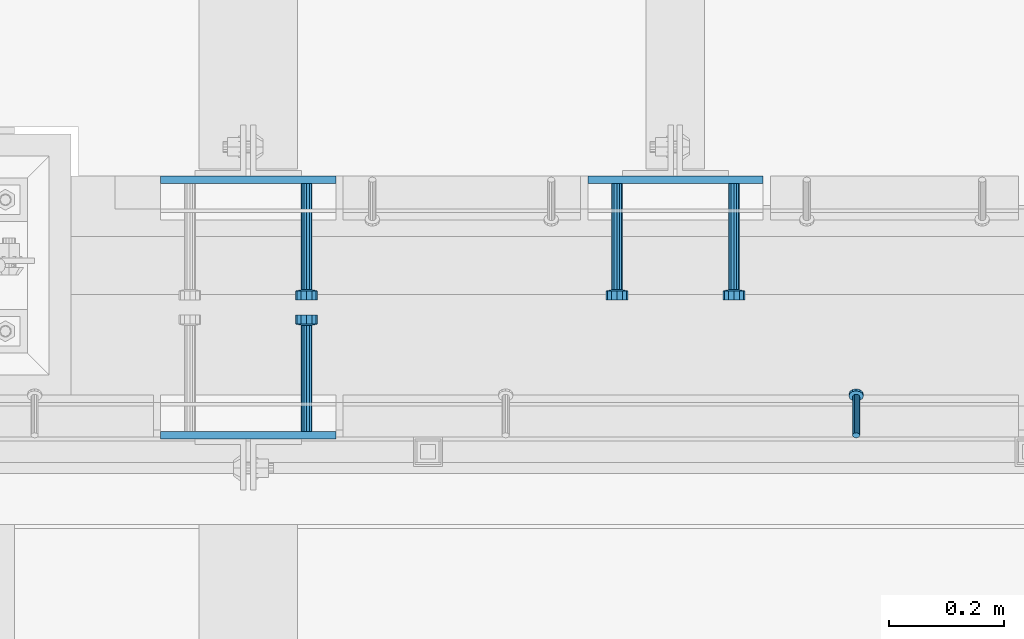
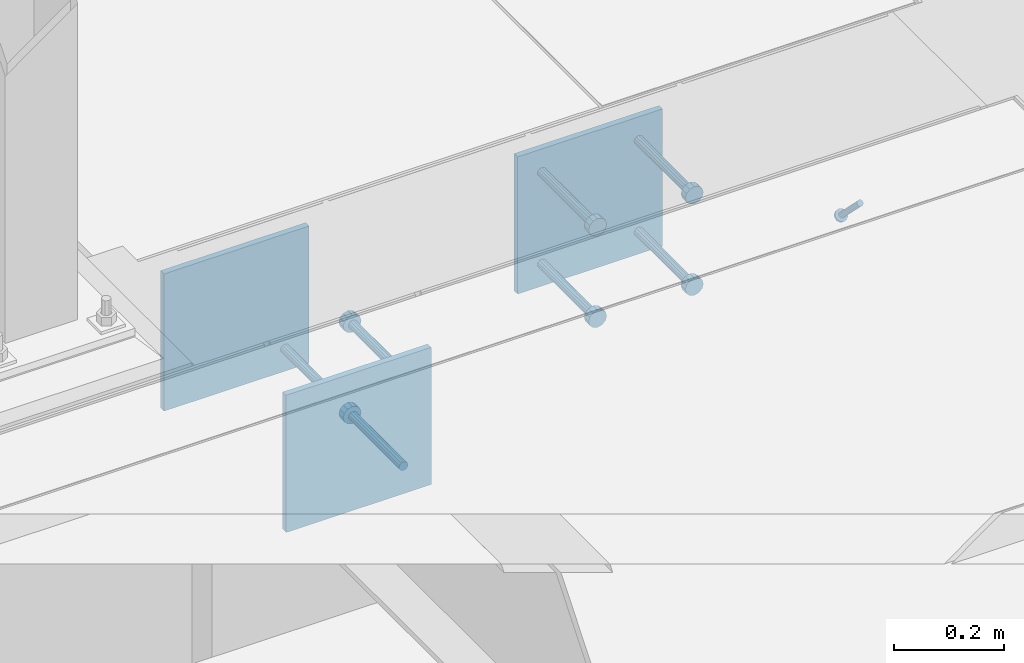
# One storey, part 2067 of 3843: 10 beams, 1 member, 4 elements without a shape of their own.
"""IFC2X3 building model written with IfcOpenShell, lengths in millimetres."""

from ifc_helpers import new_model, si_unit, frame, origin_with_axes, place, context, subcontext, project, spatial, faceted_brep, material, type_object, element, aggregate, save


model = new_model("IFC2X3")

# Units and contexts
model_context = context("Model", 3, precision=1e-05, world=origin_with_axes())
body_context = subcontext(model_context, "Body", "Model", "MODEL_VIEW")
ifc_project = project(units=[si_unit("LENGTHUNIT", "METRE", prefix="MILLI"), si_unit("AREAUNIT", "SQUARE_METRE"), si_unit("VOLUMEUNIT", "CUBIC_METRE"), si_unit("MASSUNIT", "GRAM", prefix="KILO"), si_unit("TIMEUNIT", "SECOND"), si_unit("PLANEANGLEUNIT", "RADIAN"), si_unit("SOLIDANGLEUNIT", "STERADIAN"), si_unit("THERMODYNAMICTEMPERATUREUNIT", "DEGREE_CELSIUS"), si_unit("LUMINOUSINTENSITYUNIT", "LUMEN")], contexts=[model_context])

# Site, building, storey
site_placement = place(None, origin_with_axes())
site = spatial("IfcSite", under=ifc_project, at=site_placement, CompositionType="ELEMENT")
building_placement = place(site_placement, origin_with_axes())
building = spatial("IfcBuilding", under=site, at=building_placement, Name="Undefined", CompositionType="ELEMENT")
storey_placement = place(building_placement, origin_with_axes())
storey = spatial("IfcBuildingStorey", under=building, at=storey_placement, Name="Undefined", CompositionType="ELEMENT", Elevation=0.0)

# Assembly, member
assembly_1_placement = place(storey_placement, origin_with_axes())
assembly_1 = element("IfcElementAssembly", 1, at=assembly_1_placement, inside=storey, Name="ANGLE", AssemblyPlace="NOTDEFINED", PredefinedType="RIGID_FRAME")
ifc_material_1 = material(Name="STEEL/A108")
member_type = type_object("IfcMemberType", PredefinedType="NOTDEFINED")
member_placement = place(assembly_1_placement, frame((50590.4497619755, 20012.0250010032, 30397.4500030497), z_axis=(-1.0, 0.0, 0.0), x_axis=(5.70000238222118e-08, 0.707106781186546, -0.707106781186546)))
member = element("IfcMember", 2, at=member_placement, type_object=member_type, material=ifc_material_1, Name="HEADED STUD ANCHOR", context=body_context, shape_type="Brep", body=[
    faceted_brep([(7.27595761418343e-12, -3.18000006675175, 5.5), (0.0, -5.49999999998363, 3.1800000667572), (94.4879985803855, -5.50000000011278, 3.1800000667572), (94.4879985803782, -3.18000006687362, 5.5), (0.0, -6.3499999046162, 0.0), (94.4879985803855, -6.34999990474535, 0.0), (0.0, -5.49999999998363, -3.1800000667572), (94.4879985803855, -5.50000000011278, -3.1800000667572), (7.27595761418343e-12, -3.18000006675175, -5.5), (94.4879985803782, -3.18000006687362, -5.5), (7.27595761418343e-12, -1.81898940354586e-12, -6.34999990463257), (94.4879985803782, -1.20053300634027e-10, -6.34999990463257), (0.0, 3.18000006675175, -5.5), (94.4879985803709, 3.18000006663351, -5.5), (7.27595761418343e-12, 5.49999999998363, -3.1800000667572), (94.4879985803709, 5.49999999987267, -3.1800000667572), (7.27595761418343e-12, 6.3499999046162, 0.0), (94.4879985803673, 6.34999990450706, 0.0), (7.27595761418343e-12, 5.49999999998363, 3.1800000667572), (94.4879985803709, 5.49999999987267, 3.1800000667572), (0.0, 3.18000006675175, 5.5), (94.4879985803709, 3.18000006663351, 5.5), (7.27595761418343e-12, -1.81898940354586e-12, 6.34999990463257), (94.4879985803782, -1.20053300634027e-10, 6.34999990463257), (96.5199985498621, -10.9899997712273, 6.34999990463257), (96.5199985498548, -6.34000015270249, 10.9899997711182), (96.5199985498621, -12.6999998093743, 0.0), (96.5199985498621, -10.9899997712273, -6.34999990463257), (96.5199985498548, -6.34000015270249, -10.9899997711182), (96.5199985498475, -1.21872290037572e-10, -12.6899995803833), (96.5199985498402, 6.34000015245874, -10.9899997711182), (96.519998549833, 10.9899997709817, -6.34999990463257), (96.519998549833, 12.6999998091305, 0.0), (96.519998549833, 10.9899997709817, 6.34999990463257), (96.5199985498402, 6.34000015245874, 10.9899997711182), (96.5199985498475, -1.21872290037572e-10, 12.6899995803833), (101.599998473539, -10.9899997712328, 6.34999990463257), (101.599998473532, -6.34000015270976, 10.9899997711182), (101.599998473539, -12.6999998093797, 0.0), (101.599998473539, -10.9899997712328, -6.34999990463257), (101.599998473532, -6.34000015270976, -10.9899997711182), (101.599998473524, -1.29148247651756e-10, -12.6899995803833), (101.599998473517, 6.34000015245329, -10.9899997711182), (101.59999847351, 10.9899997709763, -6.34999990463257), (101.599998473503, 12.6999998091196, 0.0), (101.59999847351, 10.9899997709763, 6.34999990463257), (101.599998473517, 6.34000015245329, 10.9899997711182), (101.599998473524, -1.29148247651756e-10, 12.6899995803833)], [[[0, 1, 2, 3]], [[1, 4, 5, 2]], [[4, 6, 7, 5]], [[6, 8, 9, 7]], [[8, 10, 11, 9]], [[10, 12, 13, 11]], [[12, 14, 15, 13]], [[14, 16, 17, 15]], [[16, 18, 19, 17]], [[18, 20, 21, 19]], [[20, 22, 23, 21]], [[22, 0, 3, 23]], [[22, 20, 18, 16, 14, 12, 10, 8, 6, 4, 1, 0]], [[3, 2, 24, 25]], [[2, 5, 26, 24]], [[5, 7, 27, 26]], [[7, 9, 28, 27]], [[9, 11, 29, 28]], [[11, 13, 30, 29]], [[13, 15, 31, 30]], [[15, 17, 32, 31]], [[17, 19, 33, 32]], [[19, 21, 34, 33]], [[21, 23, 35, 34]], [[23, 3, 25, 35]], [[25, 24, 36, 37]], [[24, 26, 38, 36]], [[26, 27, 39, 38]], [[27, 28, 40, 39]], [[28, 29, 41, 40]], [[29, 30, 42, 41]], [[30, 31, 43, 42]], [[31, 32, 44, 43]], [[32, 33, 45, 44]], [[33, 34, 46, 45]], [[34, 35, 47, 46]], [[35, 25, 37, 47]], [[38, 39, 40, 41, 42, 43, 44, 45, 46, 47, 37, 36]]]),
])
aggregate(assembly_1, [member])

# Assembly, beam
assembly_2_placement = place(storey_placement, origin_with_axes())
assembly_2 = element("IfcElementAssembly", 3, at=assembly_2_placement, inside=storey, Name="EMBED PLATE", AssemblyPlace="NOTDEFINED", PredefinedType="RIGID_FRAME")
ifc_material_2 = material(Name="STEEL/A36")
beam_type_1 = type_object("IfcBeamType", PredefinedType="NOTDEFINED")
beam_1_placement = place(assembly_2_placement, frame((49533.175, 20456.5250030517, 30397.45), z_axis=(-1.0, 0.0, 0.0), x_axis=(0.0, 0.0, -1.0)))
beam_1 = element("IfcBeam", 4, at=beam_1_placement, type_object=beam_type_1, material=ifc_material_2, Name="EMBED PLATE", context=body_context, shape_type="Brep", body=[
    faceted_brep([(-1.0550138540566e-10, 6.34999999999854, -152.400000000664), (1.0550138540566e-10, 6.34999999999854, 152.400000000656), (304.799999999999, 6.34999999999854, 152.400000000001), (304.799999999999, 6.34999999999854, -152.400000000001), (1.0550138540566e-10, -6.34999999999854, 152.400000000656), (304.799999999999, -6.34999999999854, 152.400000000001), (-1.0550138540566e-10, -6.34999999999854, -152.400000000664), (304.799999999999, -6.34999999999854, -152.400000000001)], [[[0, 1, 2, 3]], [[1, 4, 5, 2]], [[4, 6, 7, 5]], [[6, 0, 3, 7]], [[5, 7, 3, 2]], [[6, 4, 1, 0]]]),
])

assembly_3_placement = place(storey_placement, origin_with_axes())
assembly_3 = element("IfcElementAssembly", 5, at=assembly_3_placement, inside=storey, Name="EMBED PLATE", AssemblyPlace="NOTDEFINED", PredefinedType="RIGID_FRAME")
beam_2_placement = place(assembly_3_placement, frame((50276.125, 20456.5250030517, 30397.45), z_axis=(-1.0, 0.0, 0.0), x_axis=(0.0, 0.0, -1.0)))
beam_2 = element("IfcBeam", 6, at=beam_2_placement, type_object=beam_type_1, material=ifc_material_2, Name="EMBED PLATE", context=body_context, shape_type="Brep", body=[
    faceted_brep([(-1.0550138540566e-10, 6.34999999999854, -152.400000000664), (1.0550138540566e-10, 6.34999999999854, 152.400000000656), (304.799999999999, 6.34999999999854, 152.400000000001), (304.799999999999, 6.34999999999854, -152.400000000001), (1.0550138540566e-10, -6.34999999999854, 152.400000000656), (304.799999999999, -6.34999999999854, 152.400000000001), (-1.0550138540566e-10, -6.34999999999854, -152.400000000664), (304.799999999999, -6.34999999999854, -152.400000000001)], [[[0, 1, 2, 3]], [[1, 4, 5, 2]], [[4, 6, 7, 5]], [[6, 0, 3, 7]], [[5, 7, 3, 2]], [[6, 4, 1, 0]]]),
])

assembly_4_placement = place(storey_placement, origin_with_axes())
assembly_4 = element("IfcElementAssembly", 7, at=assembly_4_placement, inside=storey, Name="EMBED PLATE", AssemblyPlace="NOTDEFINED", PredefinedType="RIGID_FRAME")
beam_3_placement = place(assembly_4_placement, frame((49533.175, 20012.0249969482, 30397.45), z_axis=(1.0, 0.0, 0.0), x_axis=(0.0, 0.0, -1.0)))
beam_3 = element("IfcBeam", 8, at=beam_3_placement, type_object=beam_type_1, material=ifc_material_2, Name="EMBED PLATE", context=body_context, shape_type="Brep", body=[
    faceted_brep([(-1.0550138540566e-10, 6.34999999999854, -152.400000000664), (1.0550138540566e-10, 6.34999999999854, 152.400000000656), (304.799999999999, 6.34999999999854, 152.400000000001), (304.799999999999, 6.34999999999854, -152.400000000001), (1.0550138540566e-10, -6.34999999999854, 152.400000000656), (304.799999999999, -6.34999999999854, 152.400000000001), (-1.0550138540566e-10, -6.34999999999854, -152.400000000664), (304.799999999999, -6.34999999999854, -152.400000000001)], [[[0, 1, 2, 3]], [[1, 4, 5, 2]], [[4, 6, 7, 5]], [[6, 0, 3, 7]], [[5, 7, 3, 2]], [[6, 4, 1, 0]]]),
])

# Beam
beam_type_2 = type_object("IfcBeamType", PredefinedType="NOTDEFINED")
beam_4_placement = place(assembly_2_placement, frame((49634.775, 20450.1750030517, 30143.45), z_axis=(1.0, 0.0, 0.0), x_axis=(0.0, -1.0, 0.0)))
beam_4 = element("IfcBeam", 9, at=beam_4_placement, type_object=beam_type_2, material=ifc_material_1, Name="HEADED STUD ANCHOR", context=body_context, shape_type="Brep", body=[
    faceted_brep([(0.0, -9.52000045776367, 0.0), (0.0, -8.25, -4.76000022888184), (184.912000000004, -8.25, -4.76000022888184), (184.912000000004, -9.52000045776367, 0.0), (0.0, -4.76000022888184, -8.25), (184.912000000004, -4.76000022888184, -8.25), (0.0, 0.0, -9.52000045776367), (184.912000000004, 0.0, -9.52000045776367), (0.0, 4.76000022888184, -8.25), (184.912000000004, 4.76000022888184, -8.25), (0.0, 8.25, -4.76000022888184), (184.912000000004, 8.25, -4.76000022888184), (0.0, 9.52000045776367, 0.0), (184.912000000004, 9.52000045776367, 0.0), (0.0, 8.25, 4.76000022888184), (184.912000000004, 8.25, 4.76000022888184), (0.0, 4.76000022888184, 8.25), (184.912000000004, 4.76000022888184, 8.25), (0.0, 0.0, 9.52000045776367), (184.912000000004, 0.0, 9.52000045776367), (0.0, -4.76000022888184, 8.25), (184.912000000004, -4.76000022888184, 8.25), (0.0, -8.25, 4.76000022888184), (184.912000000004, -8.25, 4.76000022888184), (186.944000000003, -16.5, -9.52000045776367), (186.944000000003, -19.0499992370605, 0.0), (186.944000000003, -9.52000045776367, -16.5), (186.944000000003, 0.0, -19.0499992370605), (186.944000000003, 9.52000045776367, -16.5), (186.944000000003, 16.5, -9.52000045776367), (186.944000000003, 19.0499992370605, 0.0), (186.944000000003, 16.5, 9.52000045776367), (186.944000000003, 9.52000045776367, 16.5), (186.944000000003, 0.0, 19.0499992370605), (186.944000000003, -9.52000045776367, 16.5), (186.944000000003, -16.5, 9.52000045776367), (203.199999999997, -16.5, -9.52000045776367), (203.199999999997, -19.0499992370605, 0.0), (203.199999999997, -9.52000045776367, -16.5), (203.199999999997, 0.0, -19.0499992370605), (203.199999999997, 9.52000045776367, -16.5), (203.199999999997, 16.5, -9.52000045776367), (203.199999999997, 19.0499992370605, 0.0), (203.199999999997, 16.5, 9.52000045776367), (203.199999999997, 9.52000045776367, 16.5), (203.199999999997, 0.0, 19.0499992370605), (203.199999999997, -9.52000045776367, 16.5), (203.199999999997, -16.5, 9.52000045776367)], [[[0, 1, 2, 3]], [[1, 4, 5, 2]], [[4, 6, 7, 5]], [[6, 8, 9, 7]], [[8, 10, 11, 9]], [[10, 12, 13, 11]], [[12, 14, 15, 13]], [[14, 16, 17, 15]], [[16, 18, 19, 17]], [[18, 20, 21, 19]], [[20, 22, 23, 21]], [[22, 0, 3, 23]], [[22, 20, 18, 16, 14, 12, 10, 8, 6, 4, 1, 0]], [[3, 2, 24, 25]], [[2, 5, 26, 24]], [[5, 7, 27, 26]], [[7, 9, 28, 27]], [[9, 11, 29, 28]], [[11, 13, 30, 29]], [[13, 15, 31, 30]], [[15, 17, 32, 31]], [[17, 19, 33, 32]], [[19, 21, 34, 33]], [[21, 23, 35, 34]], [[23, 3, 25, 35]], [[25, 24, 36, 37]], [[24, 26, 38, 36]], [[26, 27, 39, 38]], [[27, 28, 40, 39]], [[28, 29, 41, 40]], [[29, 30, 42, 41]], [[30, 31, 43, 42]], [[31, 32, 44, 43]], [[32, 33, 45, 44]], [[33, 34, 46, 45]], [[34, 35, 47, 46]], [[35, 25, 37, 47]], [[38, 39, 40, 41, 42, 43, 44, 45, 46, 47, 37, 36]]]),
])

aggregate(assembly_2, [beam_4, beam_1])

beam_5_placement = place(assembly_3_placement, frame((50377.725, 20450.1750030517, 30346.65), z_axis=(1.0, 0.0, 0.0), x_axis=(0.0, -1.0, 0.0)))
beam_5 = element("IfcBeam", 10, at=beam_5_placement, type_object=beam_type_2, material=ifc_material_1, Name="HEADED STUD ANCHOR", context=body_context, shape_type="Brep", body=[
    faceted_brep([(0.0, -9.52000045776367, 0.0), (0.0, -8.25, -4.76000022888184), (184.912000000004, -8.25, -4.76000022888184), (184.912000000004, -9.52000045776367, 0.0), (0.0, -4.76000022888184, -8.25), (184.912000000004, -4.76000022888184, -8.25), (0.0, 0.0, -9.52000045776367), (184.912000000004, 0.0, -9.52000045776367), (0.0, 4.76000022888184, -8.25), (184.912000000004, 4.76000022888184, -8.25), (0.0, 8.25, -4.76000022888184), (184.912000000004, 8.25, -4.76000022888184), (0.0, 9.52000045776367, 0.0), (184.912000000004, 9.52000045776367, 0.0), (0.0, 8.25, 4.76000022888184), (184.912000000004, 8.25, 4.76000022888184), (0.0, 4.76000022888184, 8.25), (184.912000000004, 4.76000022888184, 8.25), (0.0, 0.0, 9.52000045776367), (184.912000000004, 0.0, 9.52000045776367), (0.0, -4.76000022888184, 8.25), (184.912000000004, -4.76000022888184, 8.25), (0.0, -8.25, 4.76000022888184), (184.912000000004, -8.25, 4.76000022888184), (186.944000000003, -16.5, -9.52000045776367), (186.944000000003, -19.0499992370605, 0.0), (186.944000000003, -9.52000045776367, -16.5), (186.944000000003, 0.0, -19.0499992370605), (186.944000000003, 9.52000045776367, -16.5), (186.944000000003, 16.5, -9.52000045776367), (186.944000000003, 19.0499992370605, 0.0), (186.944000000003, 16.5, 9.52000045776367), (186.944000000003, 9.52000045776367, 16.5), (186.944000000003, 0.0, 19.0499992370605), (186.944000000003, -9.52000045776367, 16.5), (186.944000000003, -16.5, 9.52000045776367), (203.199999999997, -16.5, -9.52000045776367), (203.199999999997, -19.0499992370605, 0.0), (203.199999999997, -9.52000045776367, -16.5), (203.199999999997, 0.0, -19.0499992370605), (203.199999999997, 9.52000045776367, -16.5), (203.199999999997, 16.5, -9.52000045776367), (203.199999999997, 19.0499992370605, 0.0), (203.199999999997, 16.5, 9.52000045776367), (203.199999999997, 9.52000045776367, 16.5), (203.199999999997, 0.0, 19.0499992370605), (203.199999999997, -9.52000045776367, 16.5), (203.199999999997, -16.5, 9.52000045776367)], [[[0, 1, 2, 3]], [[1, 4, 5, 2]], [[4, 6, 7, 5]], [[6, 8, 9, 7]], [[8, 10, 11, 9]], [[10, 12, 13, 11]], [[12, 14, 15, 13]], [[14, 16, 17, 15]], [[16, 18, 19, 17]], [[18, 20, 21, 19]], [[20, 22, 23, 21]], [[22, 0, 3, 23]], [[22, 20, 18, 16, 14, 12, 10, 8, 6, 4, 1, 0]], [[3, 2, 24, 25]], [[2, 5, 26, 24]], [[5, 7, 27, 26]], [[7, 9, 28, 27]], [[9, 11, 29, 28]], [[11, 13, 30, 29]], [[13, 15, 31, 30]], [[15, 17, 32, 31]], [[17, 19, 33, 32]], [[19, 21, 34, 33]], [[21, 23, 35, 34]], [[23, 3, 25, 35]], [[25, 24, 36, 37]], [[24, 26, 38, 36]], [[26, 27, 39, 38]], [[27, 28, 40, 39]], [[28, 29, 41, 40]], [[29, 30, 42, 41]], [[30, 31, 43, 42]], [[31, 32, 44, 43]], [[32, 33, 45, 44]], [[33, 34, 46, 45]], [[34, 35, 47, 46]], [[35, 25, 37, 47]], [[38, 39, 40, 41, 42, 43, 44, 45, 46, 47, 37, 36]]]),
])

beam_6_placement = place(assembly_3_placement, frame((50377.725, 20450.1750030517, 30143.45), z_axis=(1.0, 0.0, 0.0), x_axis=(0.0, -1.0, 0.0)))
beam_6 = element("IfcBeam", 11, at=beam_6_placement, type_object=beam_type_2, material=ifc_material_1, Name="HEADED STUD ANCHOR", context=body_context, shape_type="Brep", body=[
    faceted_brep([(0.0, -9.52000045776367, 0.0), (0.0, -8.25, -4.76000022888184), (184.912000000004, -8.25, -4.76000022888184), (184.912000000004, -9.52000045776367, 0.0), (0.0, -4.76000022888184, -8.25), (184.912000000004, -4.76000022888184, -8.25), (0.0, 0.0, -9.52000045776367), (184.912000000004, 0.0, -9.52000045776367), (0.0, 4.76000022888184, -8.25), (184.912000000004, 4.76000022888184, -8.25), (0.0, 8.25, -4.76000022888184), (184.912000000004, 8.25, -4.76000022888184), (0.0, 9.52000045776367, 0.0), (184.912000000004, 9.52000045776367, 0.0), (0.0, 8.25, 4.76000022888184), (184.912000000004, 8.25, 4.76000022888184), (0.0, 4.76000022888184, 8.25), (184.912000000004, 4.76000022888184, 8.25), (0.0, 0.0, 9.52000045776367), (184.912000000004, 0.0, 9.52000045776367), (0.0, -4.76000022888184, 8.25), (184.912000000004, -4.76000022888184, 8.25), (0.0, -8.25, 4.76000022888184), (184.912000000004, -8.25, 4.76000022888184), (186.944000000003, -16.5, -9.52000045776367), (186.944000000003, -19.0499992370605, 0.0), (186.944000000003, -9.52000045776367, -16.5), (186.944000000003, 0.0, -19.0499992370605), (186.944000000003, 9.52000045776367, -16.5), (186.944000000003, 16.5, -9.52000045776367), (186.944000000003, 19.0499992370605, 0.0), (186.944000000003, 16.5, 9.52000045776367), (186.944000000003, 9.52000045776367, 16.5), (186.944000000003, 0.0, 19.0499992370605), (186.944000000003, -9.52000045776367, 16.5), (186.944000000003, -16.5, 9.52000045776367), (203.199999999997, -16.5, -9.52000045776367), (203.199999999997, -19.0499992370605, 0.0), (203.199999999997, -9.52000045776367, -16.5), (203.199999999997, 0.0, -19.0499992370605), (203.199999999997, 9.52000045776367, -16.5), (203.199999999997, 16.5, -9.52000045776367), (203.199999999997, 19.0499992370605, 0.0), (203.199999999997, 16.5, 9.52000045776367), (203.199999999997, 9.52000045776367, 16.5), (203.199999999997, 0.0, 19.0499992370605), (203.199999999997, -9.52000045776367, 16.5), (203.199999999997, -16.5, 9.52000045776367)], [[[0, 1, 2, 3]], [[1, 4, 5, 2]], [[4, 6, 7, 5]], [[6, 8, 9, 7]], [[8, 10, 11, 9]], [[10, 12, 13, 11]], [[12, 14, 15, 13]], [[14, 16, 17, 15]], [[16, 18, 19, 17]], [[18, 20, 21, 19]], [[20, 22, 23, 21]], [[22, 0, 3, 23]], [[22, 20, 18, 16, 14, 12, 10, 8, 6, 4, 1, 0]], [[3, 2, 24, 25]], [[2, 5, 26, 24]], [[5, 7, 27, 26]], [[7, 9, 28, 27]], [[9, 11, 29, 28]], [[11, 13, 30, 29]], [[13, 15, 31, 30]], [[15, 17, 32, 31]], [[17, 19, 33, 32]], [[19, 21, 34, 33]], [[21, 23, 35, 34]], [[23, 3, 25, 35]], [[25, 24, 36, 37]], [[24, 26, 38, 36]], [[26, 27, 39, 38]], [[27, 28, 40, 39]], [[28, 29, 41, 40]], [[29, 30, 42, 41]], [[30, 31, 43, 42]], [[31, 32, 44, 43]], [[32, 33, 45, 44]], [[33, 34, 46, 45]], [[34, 35, 47, 46]], [[35, 25, 37, 47]], [[38, 39, 40, 41, 42, 43, 44, 45, 46, 47, 37, 36]]]),
])

beam_7_placement = place(assembly_3_placement, frame((50174.525, 20450.1750030517, 30346.65), z_axis=(1.0, 0.0, 0.0), x_axis=(0.0, -1.0, 0.0)))
beam_7 = element("IfcBeam", 12, at=beam_7_placement, type_object=beam_type_2, material=ifc_material_2, Name="PLATE", context=body_context, shape_type="Brep", body=[
    faceted_brep([(0.0, -9.52000045776367, 0.0), (0.0, -8.25, -4.76000022888184), (184.912000000004, -8.25, -4.76000022888184), (184.912000000004, -9.52000045776367, 0.0), (0.0, -4.76000022888184, -8.25), (184.912000000004, -4.76000022888184, -8.25), (0.0, 0.0, -9.52000045776367), (184.912000000004, 0.0, -9.52000045776367), (0.0, 4.76000022888184, -8.25), (184.912000000004, 4.76000022888184, -8.25), (0.0, 8.25, -4.76000022888184), (184.912000000004, 8.25, -4.76000022888184), (0.0, 9.52000045776367, 0.0), (184.912000000004, 9.52000045776367, 0.0), (0.0, 8.25, 4.76000022888184), (184.912000000004, 8.25, 4.76000022888184), (0.0, 4.76000022888184, 8.25), (184.912000000004, 4.76000022888184, 8.25), (0.0, 0.0, 9.52000045776367), (184.912000000004, 0.0, 9.52000045776367), (0.0, -4.76000022888184, 8.25), (184.912000000004, -4.76000022888184, 8.25), (0.0, -8.25, 4.76000022888184), (184.912000000004, -8.25, 4.76000022888184), (186.944000000003, -16.5, -9.52000045776367), (186.944000000003, -19.0499992370605, 0.0), (186.944000000003, -9.52000045776367, -16.5), (186.944000000003, 0.0, -19.0499992370605), (186.944000000003, 9.52000045776367, -16.5), (186.944000000003, 16.5, -9.52000045776367), (186.944000000003, 19.0499992370605, 0.0), (186.944000000003, 16.5, 9.52000045776367), (186.944000000003, 9.52000045776367, 16.5), (186.944000000003, 0.0, 19.0499992370605), (186.944000000003, -9.52000045776367, 16.5), (186.944000000003, -16.5, 9.52000045776367), (203.199999999997, -16.5, -9.52000045776367), (203.199999999997, -19.0499992370605, 0.0), (203.199999999997, -9.52000045776367, -16.5), (203.199999999997, 0.0, -19.0499992370605), (203.199999999997, 9.52000045776367, -16.5), (203.199999999997, 16.5, -9.52000045776367), (203.199999999997, 19.0499992370605, 0.0), (203.199999999997, 16.5, 9.52000045776367), (203.199999999997, 9.52000045776367, 16.5), (203.199999999997, 0.0, 19.0499992370605), (203.199999999997, -9.52000045776367, 16.5), (203.199999999997, -16.5, 9.52000045776367)], [[[0, 1, 2, 3]], [[1, 4, 5, 2]], [[4, 6, 7, 5]], [[6, 8, 9, 7]], [[8, 10, 11, 9]], [[10, 12, 13, 11]], [[12, 14, 15, 13]], [[14, 16, 17, 15]], [[16, 18, 19, 17]], [[18, 20, 21, 19]], [[20, 22, 23, 21]], [[22, 0, 3, 23]], [[22, 20, 18, 16, 14, 12, 10, 8, 6, 4, 1, 0]], [[3, 2, 24, 25]], [[2, 5, 26, 24]], [[5, 7, 27, 26]], [[7, 9, 28, 27]], [[9, 11, 29, 28]], [[11, 13, 30, 29]], [[13, 15, 31, 30]], [[15, 17, 32, 31]], [[17, 19, 33, 32]], [[19, 21, 34, 33]], [[21, 23, 35, 34]], [[23, 3, 25, 35]], [[25, 24, 36, 37]], [[24, 26, 38, 36]], [[26, 27, 39, 38]], [[27, 28, 40, 39]], [[28, 29, 41, 40]], [[29, 30, 42, 41]], [[30, 31, 43, 42]], [[31, 32, 44, 43]], [[32, 33, 45, 44]], [[33, 34, 46, 45]], [[34, 35, 47, 46]], [[35, 25, 37, 47]], [[38, 39, 40, 41, 42, 43, 44, 45, 46, 47, 37, 36]]]),
])

beam_8_placement = place(assembly_3_placement, frame((50174.525, 20450.1750030517, 30143.45), z_axis=(1.0, 0.0, 0.0), x_axis=(0.0, -1.0, 0.0)))
beam_8 = element("IfcBeam", 13, at=beam_8_placement, type_object=beam_type_2, material=ifc_material_1, Name="HEADED STUD ANCHOR", context=body_context, shape_type="Brep", body=[
    faceted_brep([(0.0, -9.52000045776367, 0.0), (0.0, -8.25, -4.76000022888184), (184.912000000004, -8.25, -4.76000022888184), (184.912000000004, -9.52000045776367, 0.0), (0.0, -4.76000022888184, -8.25), (184.912000000004, -4.76000022888184, -8.25), (0.0, 0.0, -9.52000045776367), (184.912000000004, 0.0, -9.52000045776367), (0.0, 4.76000022888184, -8.25), (184.912000000004, 4.76000022888184, -8.25), (0.0, 8.25, -4.76000022888184), (184.912000000004, 8.25, -4.76000022888184), (0.0, 9.52000045776367, 0.0), (184.912000000004, 9.52000045776367, 0.0), (0.0, 8.25, 4.76000022888184), (184.912000000004, 8.25, 4.76000022888184), (0.0, 4.76000022888184, 8.25), (184.912000000004, 4.76000022888184, 8.25), (0.0, 0.0, 9.52000045776367), (184.912000000004, 0.0, 9.52000045776367), (0.0, -4.76000022888184, 8.25), (184.912000000004, -4.76000022888184, 8.25), (0.0, -8.25, 4.76000022888184), (184.912000000004, -8.25, 4.76000022888184), (186.944000000003, -16.5, -9.52000045776367), (186.944000000003, -19.0499992370605, 0.0), (186.944000000003, -9.52000045776367, -16.5), (186.944000000003, 0.0, -19.0499992370605), (186.944000000003, 9.52000045776367, -16.5), (186.944000000003, 16.5, -9.52000045776367), (186.944000000003, 19.0499992370605, 0.0), (186.944000000003, 16.5, 9.52000045776367), (186.944000000003, 9.52000045776367, 16.5), (186.944000000003, 0.0, 19.0499992370605), (186.944000000003, -9.52000045776367, 16.5), (186.944000000003, -16.5, 9.52000045776367), (203.199999999997, -16.5, -9.52000045776367), (203.199999999997, -19.0499992370605, 0.0), (203.199999999997, -9.52000045776367, -16.5), (203.199999999997, 0.0, -19.0499992370605), (203.199999999997, 9.52000045776367, -16.5), (203.199999999997, 16.5, -9.52000045776367), (203.199999999997, 19.0499992370605, 0.0), (203.199999999997, 16.5, 9.52000045776367), (203.199999999997, 9.52000045776367, 16.5), (203.199999999997, 0.0, 19.0499992370605), (203.199999999997, -9.52000045776367, 16.5), (203.199999999997, -16.5, 9.52000045776367)], [[[0, 1, 2, 3]], [[1, 4, 5, 2]], [[4, 6, 7, 5]], [[6, 8, 9, 7]], [[8, 10, 11, 9]], [[10, 12, 13, 11]], [[12, 14, 15, 13]], [[14, 16, 17, 15]], [[16, 18, 19, 17]], [[18, 20, 21, 19]], [[20, 22, 23, 21]], [[22, 0, 3, 23]], [[22, 20, 18, 16, 14, 12, 10, 8, 6, 4, 1, 0]], [[3, 2, 24, 25]], [[2, 5, 26, 24]], [[5, 7, 27, 26]], [[7, 9, 28, 27]], [[9, 11, 29, 28]], [[11, 13, 30, 29]], [[13, 15, 31, 30]], [[15, 17, 32, 31]], [[17, 19, 33, 32]], [[19, 21, 34, 33]], [[21, 23, 35, 34]], [[23, 3, 25, 35]], [[25, 24, 36, 37]], [[24, 26, 38, 36]], [[26, 27, 39, 38]], [[27, 28, 40, 39]], [[28, 29, 41, 40]], [[29, 30, 42, 41]], [[30, 31, 43, 42]], [[31, 32, 44, 43]], [[32, 33, 45, 44]], [[33, 34, 46, 45]], [[34, 35, 47, 46]], [[35, 25, 37, 47]], [[38, 39, 40, 41, 42, 43, 44, 45, 46, 47, 37, 36]]]),
])

aggregate(assembly_3, [beam_5, beam_6, beam_7, beam_8, beam_2])

beam_9_placement = place(assembly_4_placement, frame((49634.775, 20018.3749969482, 30346.65), z_axis=(-1.0, 0.0, 0.0), x_axis=(0.0, 1.0, 0.0)))
beam_9 = element("IfcBeam", 14, at=beam_9_placement, type_object=beam_type_2, material=ifc_material_2, Name="PLATE", context=body_context, shape_type="Brep", body=[
    faceted_brep([(0.0, -9.52000045776367, 0.0), (0.0, -8.25, -4.76000022888184), (184.912000000004, -8.25, -4.76000022888184), (184.912000000004, -9.52000045776367, 0.0), (0.0, -4.76000022888184, -8.25), (184.912000000004, -4.76000022888184, -8.25), (0.0, 0.0, -9.52000045776367), (184.912000000004, 0.0, -9.52000045776367), (0.0, 4.76000022888184, -8.25), (184.912000000004, 4.76000022888184, -8.25), (0.0, 8.25, -4.76000022888184), (184.912000000004, 8.25, -4.76000022888184), (0.0, 9.52000045776367, 0.0), (184.912000000004, 9.52000045776367, 0.0), (0.0, 8.25, 4.76000022888184), (184.912000000004, 8.25, 4.76000022888184), (0.0, 4.76000022888184, 8.25), (184.912000000004, 4.76000022888184, 8.25), (0.0, 0.0, 9.52000045776367), (184.912000000004, 0.0, 9.52000045776367), (0.0, -4.76000022888184, 8.25), (184.912000000004, -4.76000022888184, 8.25), (0.0, -8.25, 4.76000022888184), (184.912000000004, -8.25, 4.76000022888184), (186.944000000003, -16.5, -9.52000045776367), (186.944000000003, -19.0499992370605, 0.0), (186.944000000003, -9.52000045776367, -16.5), (186.944000000003, 0.0, -19.0499992370605), (186.944000000003, 9.52000045776367, -16.5), (186.944000000003, 16.5, -9.52000045776367), (186.944000000003, 19.0499992370605, 0.0), (186.944000000003, 16.5, 9.52000045776367), (186.944000000003, 9.52000045776367, 16.5), (186.944000000003, 0.0, 19.0499992370605), (186.944000000003, -9.52000045776367, 16.5), (186.944000000003, -16.5, 9.52000045776367), (203.199999999997, -16.5, -9.52000045776367), (203.199999999997, -19.0499992370605, 0.0), (203.199999999997, -9.52000045776367, -16.5), (203.199999999997, 0.0, -19.0499992370605), (203.199999999997, 9.52000045776367, -16.5), (203.199999999997, 16.5, -9.52000045776367), (203.199999999997, 19.0499992370605, 0.0), (203.199999999997, 16.5, 9.52000045776367), (203.199999999997, 9.52000045776367, 16.5), (203.199999999997, 0.0, 19.0499992370605), (203.199999999997, -9.52000045776367, 16.5), (203.199999999997, -16.5, 9.52000045776367)], [[[0, 1, 2, 3]], [[1, 4, 5, 2]], [[4, 6, 7, 5]], [[6, 8, 9, 7]], [[8, 10, 11, 9]], [[10, 12, 13, 11]], [[12, 14, 15, 13]], [[14, 16, 17, 15]], [[16, 18, 19, 17]], [[18, 20, 21, 19]], [[20, 22, 23, 21]], [[22, 0, 3, 23]], [[22, 20, 18, 16, 14, 12, 10, 8, 6, 4, 1, 0]], [[3, 2, 24, 25]], [[2, 5, 26, 24]], [[5, 7, 27, 26]], [[7, 9, 28, 27]], [[9, 11, 29, 28]], [[11, 13, 30, 29]], [[13, 15, 31, 30]], [[15, 17, 32, 31]], [[17, 19, 33, 32]], [[19, 21, 34, 33]], [[21, 23, 35, 34]], [[23, 3, 25, 35]], [[25, 24, 36, 37]], [[24, 26, 38, 36]], [[26, 27, 39, 38]], [[27, 28, 40, 39]], [[28, 29, 41, 40]], [[29, 30, 42, 41]], [[30, 31, 43, 42]], [[31, 32, 44, 43]], [[32, 33, 45, 44]], [[33, 34, 46, 45]], [[34, 35, 47, 46]], [[35, 25, 37, 47]], [[38, 39, 40, 41, 42, 43, 44, 45, 46, 47, 37, 36]]]),
])

beam_10_placement = place(assembly_4_placement, frame((49634.775, 20018.3749969482, 30143.45), z_axis=(-1.0, 0.0, 0.0), x_axis=(0.0, 1.0, 0.0)))
beam_10 = element("IfcBeam", 15, at=beam_10_placement, type_object=beam_type_2, material=ifc_material_1, Name="HEADED STUD ANCHOR", context=body_context, shape_type="Brep", body=[
    faceted_brep([(0.0, -9.52000045776367, 0.0), (0.0, -8.25, -4.76000022888184), (184.912000000004, -8.25, -4.76000022888184), (184.912000000004, -9.52000045776367, 0.0), (0.0, -4.76000022888184, -8.25), (184.912000000004, -4.76000022888184, -8.25), (0.0, 0.0, -9.52000045776367), (184.912000000004, 0.0, -9.52000045776367), (0.0, 4.76000022888184, -8.25), (184.912000000004, 4.76000022888184, -8.25), (0.0, 8.25, -4.76000022888184), (184.912000000004, 8.25, -4.76000022888184), (0.0, 9.52000045776367, 0.0), (184.912000000004, 9.52000045776367, 0.0), (0.0, 8.25, 4.76000022888184), (184.912000000004, 8.25, 4.76000022888184), (0.0, 4.76000022888184, 8.25), (184.912000000004, 4.76000022888184, 8.25), (0.0, 0.0, 9.52000045776367), (184.912000000004, 0.0, 9.52000045776367), (0.0, -4.76000022888184, 8.25), (184.912000000004, -4.76000022888184, 8.25), (0.0, -8.25, 4.76000022888184), (184.912000000004, -8.25, 4.76000022888184), (186.944000000003, -16.5, -9.52000045776367), (186.944000000003, -19.0499992370605, 0.0), (186.944000000003, -9.52000045776367, -16.5), (186.944000000003, 0.0, -19.0499992370605), (186.944000000003, 9.52000045776367, -16.5), (186.944000000003, 16.5, -9.52000045776367), (186.944000000003, 19.0499992370605, 0.0), (186.944000000003, 16.5, 9.52000045776367), (186.944000000003, 9.52000045776367, 16.5), (186.944000000003, 0.0, 19.0499992370605), (186.944000000003, -9.52000045776367, 16.5), (186.944000000003, -16.5, 9.52000045776367), (203.199999999997, -16.5, -9.52000045776367), (203.199999999997, -19.0499992370605, 0.0), (203.199999999997, -9.52000045776367, -16.5), (203.199999999997, 0.0, -19.0499992370605), (203.199999999997, 9.52000045776367, -16.5), (203.199999999997, 16.5, -9.52000045776367), (203.199999999997, 19.0499992370605, 0.0), (203.199999999997, 16.5, 9.52000045776367), (203.199999999997, 9.52000045776367, 16.5), (203.199999999997, 0.0, 19.0499992370605), (203.199999999997, -9.52000045776367, 16.5), (203.199999999997, -16.5, 9.52000045776367)], [[[0, 1, 2, 3]], [[1, 4, 5, 2]], [[4, 6, 7, 5]], [[6, 8, 9, 7]], [[8, 10, 11, 9]], [[10, 12, 13, 11]], [[12, 14, 15, 13]], [[14, 16, 17, 15]], [[16, 18, 19, 17]], [[18, 20, 21, 19]], [[20, 22, 23, 21]], [[22, 0, 3, 23]], [[22, 20, 18, 16, 14, 12, 10, 8, 6, 4, 1, 0]], [[3, 2, 24, 25]], [[2, 5, 26, 24]], [[5, 7, 27, 26]], [[7, 9, 28, 27]], [[9, 11, 29, 28]], [[11, 13, 30, 29]], [[13, 15, 31, 30]], [[15, 17, 32, 31]], [[17, 19, 33, 32]], [[19, 21, 34, 33]], [[21, 23, 35, 34]], [[23, 3, 25, 35]], [[25, 24, 36, 37]], [[24, 26, 38, 36]], [[26, 27, 39, 38]], [[27, 28, 40, 39]], [[28, 29, 41, 40]], [[29, 30, 42, 41]], [[30, 31, 43, 42]], [[31, 32, 44, 43]], [[32, 33, 45, 44]], [[33, 34, 46, 45]], [[34, 35, 47, 46]], [[35, 25, 37, 47]], [[38, 39, 40, 41, 42, 43, 44, 45, 46, 47, 37, 36]]]),
])

aggregate(assembly_4, [beam_9, beam_10, beam_3])

save(model, "model.ifc")
